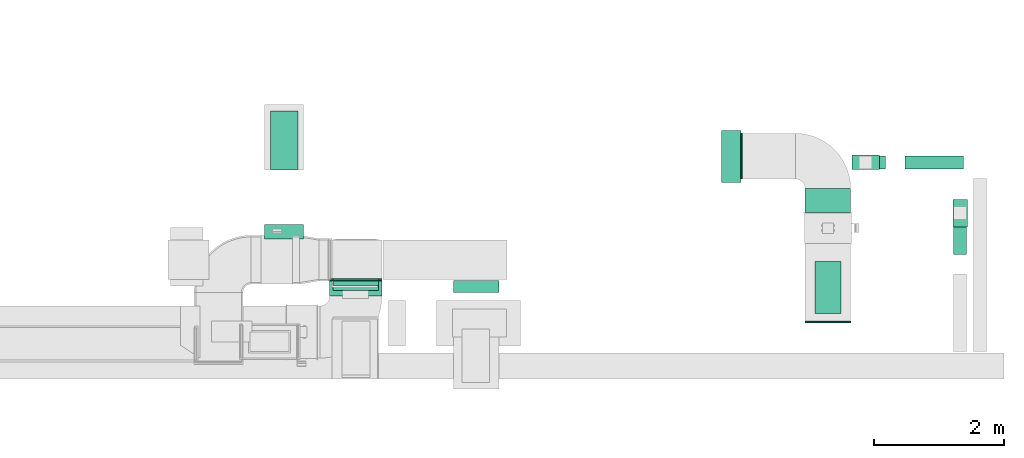
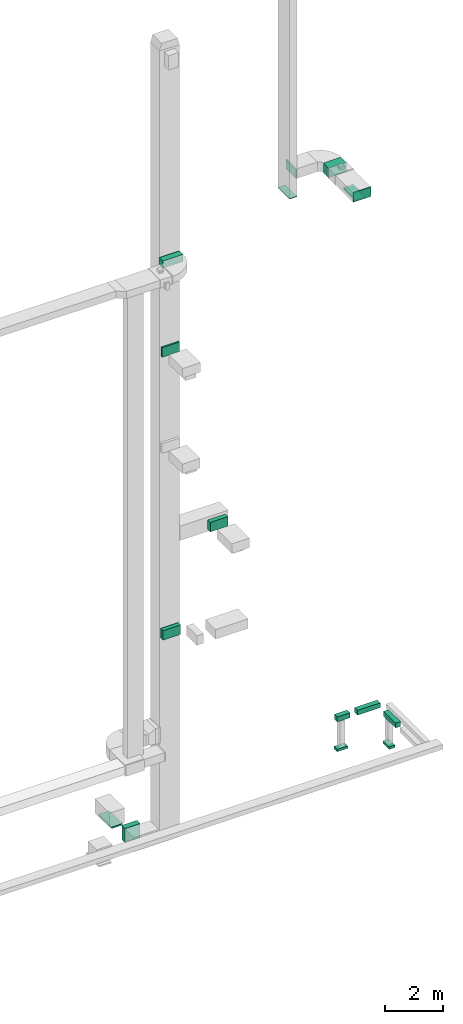
# One storey, part 17 of 29: 13 flow segments, 6 flow fittings, 1 flow terminal.
"""IFC2X3 building model written with IfcOpenShell, lengths in millimetres."""

from ifc_helpers import new_model, entity, si_unit, converted_unit, derived_unit, direction, frame, frame_2d, origin, origin_2d_with_axis, place, context, subcontext, project, spatial, rectangle, extrude, source, transform, mapped, material, type_object, type_shapes, element, save


model = new_model("IFC2X3")

# Units and contexts
model_context = context("Model", 3, precision=0.01, world=origin(), true_north=direction((6.12303176911189e-17, 1.0)))
body_context = subcontext(model_context, "Body", "Model", "MODEL_VIEW")
ifc_project = project(units=[si_unit("LENGTHUNIT", "METRE", prefix="MILLI"), si_unit("AREAUNIT", "SQUARE_METRE"), si_unit("VOLUMEUNIT", "CUBIC_METRE"), converted_unit("PLANEANGLEUNIT", "DEGREE", entity("IfcRatioMeasure", 0.0174532925199433), si_unit("PLANEANGLEUNIT", "RADIAN"), dimensions=[0, 0, 0, 0, 0, 0, 0]), si_unit("MASSUNIT", "GRAM", prefix="KILO"), derived_unit("MASSDENSITYUNIT", [(si_unit("MASSUNIT", "GRAM", prefix="KILO"), 1), (si_unit("LENGTHUNIT", "METRE"), -3)]), derived_unit("MOMENTOFINERTIAUNIT", [(si_unit("LENGTHUNIT", "METRE"), 4)]), si_unit("TIMEUNIT", "SECOND"), si_unit("FREQUENCYUNIT", "HERTZ"), si_unit("THERMODYNAMICTEMPERATUREUNIT", "DEGREE_CELSIUS"), derived_unit("THERMALTRANSMITTANCEUNIT", [(si_unit("MASSUNIT", "GRAM", prefix="KILO"), 1), (si_unit("THERMODYNAMICTEMPERATUREUNIT", "KELVIN"), -1), (si_unit("TIMEUNIT", "SECOND"), -3)]), derived_unit("VOLUMETRICFLOWRATEUNIT", [(si_unit("LENGTHUNIT", "METRE"), 3), (si_unit("TIMEUNIT", "SECOND"), -1)]), derived_unit("MASSFLOWRATEUNIT", [(si_unit("MASSUNIT", "GRAM", prefix="KILO"), 1), (si_unit("TIMEUNIT", "SECOND"), -1)]), derived_unit("ROTATIONALFREQUENCYUNIT", [(si_unit("TIMEUNIT", "SECOND"), -1)]), si_unit("ELECTRICCURRENTUNIT", "AMPERE"), si_unit("ELECTRICVOLTAGEUNIT", "VOLT"), si_unit("POWERUNIT", "WATT"), si_unit("FORCEUNIT", "NEWTON", prefix="KILO"), si_unit("ILLUMINANCEUNIT", "LUX"), si_unit("LUMINOUSFLUXUNIT", "LUMEN"), si_unit("LUMINOUSINTENSITYUNIT", "CANDELA"), derived_unit("USERDEFINED", [(si_unit("MASSUNIT", "GRAM", prefix="KILO"), -1), (si_unit("LENGTHUNIT", "METRE"), -2), (si_unit("TIMEUNIT", "SECOND"), 3), (si_unit("LUMINOUSFLUXUNIT", "LUMEN"), 1)]), derived_unit("LINEARVELOCITYUNIT", [(si_unit("LENGTHUNIT", "METRE"), 1), (si_unit("TIMEUNIT", "SECOND"), -1)]), si_unit("PRESSUREUNIT", "PASCAL"), derived_unit("USERDEFINED", [(si_unit("LENGTHUNIT", "METRE"), -2), (si_unit("MASSUNIT", "GRAM", prefix="KILO"), 1), (si_unit("TIMEUNIT", "SECOND"), -2)]), derived_unit("LINEARFORCEUNIT", [(si_unit("MASSUNIT", "GRAM", prefix="KILO"), 1), (si_unit("LENGTHUNIT", "METRE"), 1), (si_unit("TIMEUNIT", "SECOND"), -2), (si_unit("LENGTHUNIT", "METRE"), -1)]), derived_unit("PLANARFORCEUNIT", [(si_unit("MASSUNIT", "GRAM", prefix="KILO"), 1), (si_unit("LENGTHUNIT", "METRE"), 1), (si_unit("TIMEUNIT", "SECOND"), -2), (si_unit("LENGTHUNIT", "METRE"), -2)])], contexts=[model_context])

# Site, building, storey
site_placement = place(None, frame((0.0, -0.00077364408347762, 0.0)))
site = spatial("IfcSite", under=ifc_project, at=site_placement, CompositionType="ELEMENT")
building_placement = place(site_placement, origin())
building = spatial("IfcBuilding", under=site, at=building_placement, CompositionType="ELEMENT")
storey_placement = place(building_placement, origin())
storey = spatial("IfcBuildingStorey", under=building, at=storey_placement, CompositionType="ELEMENT", Elevation=0.0)

# Flow segments
duct_segment_type = type_object("IfcDuctSegmentType", PredefinedType="NOTDEFINED")
flow_segment_1_placement = place(storey_placement, frame((69919.8966022687, 9984.96833649774, 22730.0)))
element("IfcFlowSegment", 1, at=flow_segment_1_placement, inside=storey, type_object=duct_segment_type, context=body_context, shape_type="SweptSolid", body=[
    extrude(rectangle(XDim=800.0, YDim=400.000000000004, at=origin_2d_with_axis()), frame((200.0, 400.0, 0.0), z_axis=(0.0, 0.0, 1.0), x_axis=(0.0, 1.0, 0.0)), (0.0, 0.0, 1.0), 50.000000000006),
])
flow_segment_2_placement = place(storey_placement, frame((69769.8966022687, 11535.0, 22800.0)))
element("IfcFlowSegment", 2, at=flow_segment_2_placement, inside=storey, type_object=duct_segment_type, context=body_context, shape_type="SweptSolid", body=[
    extrude(rectangle(XDim=364.595053180721, YDim=699.999999999997, at=frame_2d((0.0, 4.32009983342141e-12), x_axis=(1.0, 0.0))), frame((350.0, 182.297526590368, 0.0), z_axis=(0.0, 0.0, 1.0), x_axis=(0.0, -1.0, 0.0)), (0.0, 0.0, 1.0), 399.999999999996),
])
flow_segment_3_placement = place(storey_placement, frame((61557.6339475038, 12193.4990444987, -1980.0)))
element("IfcFlowSegment", 3, at=flow_segment_3_placement, inside=storey, type_object=duct_segment_type, context=body_context, shape_type="SweptSolid", body=[
    extrude(rectangle(XDim=900.0, YDim=425.000000000004, at=frame_2d((-1.08002495835535e-12, 0.0), x_axis=(1.0, 0.0))), frame((212.502047009256, 450.000966639643, 0.0), z_axis=(0.0, 0.0, 1.0), x_axis=(4.54891432006358e-06, 1.0, 0.0)), (0.0, 0.0, 1.0), 60.4869889686039),
])
flow_segment_4_placement = place(storey_placement, frame((61470.135994513, 11128.5000111377, -1899.51301103141)))
element("IfcFlowSegment", 4, at=flow_segment_4_placement, inside=storey, type_object=duct_segment_type, context=body_context, shape_type="SweptSolid", body=[
    extrude(rectangle(XDim=221.220937838014, YDim=600.000000000002, at=frame_2d((1.08002495835535e-12, 0.0), x_axis=(1.0, 0.0))), frame((300.0, 110.610468919006, 0.0), z_axis=(0.0, 0.0, 1.0), x_axis=(0.0, 1.0, 0.0)), (0.0, 0.0, 1.0), 600.0),
])
flow_segment_5_placement = place(storey_placement, frame((72050.4589684754, 10887.2569885968, -650.0)))
element("IfcFlowSegment", 5, at=flow_segment_5_placement, inside=storey, type_object=duct_segment_type, context=body_context, shape_type="SweptSolid", body=[
    extrude(rectangle(XDim=834.396194023908, YDim=199.999999999998, at=frame_2d((-1.08002495835535e-12, -4.33431068813661e-12), x_axis=(1.0, 0.0))), frame((100.0, 417.198097011955, 0.0), z_axis=(0.0, 0.0, 1.0), x_axis=(0.0, 1.0, 0.0)), (0.0, 0.0, 1.0), 200.0),
])
flow_segment_6_placement = place(storey_placement, frame((70499.2346294125, 12205.499847268, -650.0)))
element("IfcFlowSegment", 6, at=flow_segment_6_placement, inside=storey, type_object=duct_segment_type, context=body_context, shape_type="SweptSolid", body=[
    extrude(rectangle(XDim=507.012116293382, YDim=200.0, at=frame_2d((-4.33431068813661e-12, -1.08713038571295e-12), x_axis=(1.0, 0.0))), frame((253.506058146695, 100.0, 0.0), z_axis=(0.0, 0.0, 1.0), x_axis=(-1.0, 0.0, 0.0)), (0.0, 0.0, 1.0), 200.0),
])
flow_segment_7_placement = place(storey_placement, frame((71306.2467457059, 12205.499847268, -650.0)))
element("IfcFlowSegment", 7, at=flow_segment_7_placement, inside=storey, type_object=duct_segment_type, context=body_context, shape_type="SweptSolid", body=[
    extrude(rectangle(XDim=898.086611318234, YDim=200.0, at=frame_2d((4.34852154285181e-12, 2.16715534406831e-12), x_axis=(1.0, 0.0))), frame((449.043305659121, 100.0, 0.0), z_axis=(0.0, 0.0, 1.0), x_axis=(-1.0, 0.0, 0.0)), (0.0, 0.0, 1.0), 200.0),
])
flow_segment_8_placement = place(storey_placement, frame((72037.9589684754, 11312.4032421629, -1800.0)))
element("IfcFlowSegment", 8, at=flow_segment_8_placement, inside=storey, type_object=duct_segment_type, context=body_context, shape_type="SweptSolid", body=[
    extrude(rectangle(XDim=425.000000000007, YDim=225.000000000001, at=origin_2d_with_axis()), frame((112.5, 212.500000000004, 0.0), z_axis=(0.0, 0.0, 1.0), x_axis=(0.0, -1.0, 0.0)), (0.0, 0.0, 1.0), 100.0),
])
flow_segment_9_placement = place(storey_placement, frame((70486.7346294125, 12192.999847268, -1894.0)))
element("IfcFlowSegment", 9, at=flow_segment_9_placement, inside=storey, type_object=duct_segment_type, context=body_context, shape_type="SweptSolid", body=[
    extrude(rectangle(XDim=425.000000000007, YDim=225.000000000001, at=frame_2d((0.0, 1.08002495835535e-12), x_axis=(1.0, 0.0))), frame((212.500000000004, 112.5, 0.0)), (0.0, 0.0, 1.0), 100.0),
])
flow_segment_10_placement = place(storey_placement, frame((62518.988759683, 10412.601109398, 18500.0)))
element("IfcFlowSegment", 10, at=flow_segment_10_placement, inside=storey, type_object=duct_segment_type, context=body_context, shape_type="SweptSolid", body=[
    extrude(rectangle(XDim=71.0457855893592, YDim=700.000000000003, at=origin_2d_with_axis()), frame((350.005588994264, 35.5780023522402, 0.0), z_axis=(0.0, 0.0, 1.0), x_axis=(-0.000157457136900827, 0.999999987603625, 0.0)), (0.0, 0.0, 1.0), 400.0),
])
flow_segment_11_placement = place(storey_placement, frame((62469.7193441226, 10248.8325484295, 22350.0)))
element("IfcFlowSegment", 11, at=flow_segment_11_placement, inside=storey, type_object=duct_segment_type, context=body_context, shape_type="SweptSolid", body=[
    extrude(rectangle(XDim=239.665570609249, YDim=800.000000000004, at=frame_2d((1.08713038571295e-12, 4.32009983342141e-12), x_axis=(1.0, 0.0))), frame((400.000412244298, 119.834161376974, 0.0), z_axis=(0.0, 0.0, 1.0), x_axis=(-3.44018263539569e-06, -1.0, 0.0)), (0.0, 0.0, 1.0), 300.000000000001),
])
flow_segment_12_placement = place(storey_placement, frame((62520.6816618024, 10335.385873386, 6700.0)))
element("IfcFlowSegment", 12, at=flow_segment_12_placement, inside=storey, type_object=duct_segment_type, context=body_context, shape_type="SweptSolid", body=[
    extrude(rectangle(XDim=153.114137751644, YDim=699.999999999997, at=frame_2d((0.0, -4.32009983342141e-12), x_axis=(1.0, 0.0))), frame((350.0, 76.5570688758424, 0.0), z_axis=(0.0, 0.0, 1.0), x_axis=(0.0, 1.0, 0.0)), (0.0, 0.0, 1.0), 400.0),
])
flow_segment_13_placement = place(storey_placement, frame((64372.3098713498, 10305.6563298071, 10600.0)))
element("IfcFlowSegment", 13, at=flow_segment_13_placement, inside=storey, type_object=duct_segment_type, context=body_context, shape_type="SweptSolid", body=[
    extrude(rectangle(XDim=182.843681330892, YDim=699.999999999997, at=frame_2d((1.08713038571295e-12, 0.0), x_axis=(1.0, 0.0))), frame((350.0, 91.421840665447, 0.0), z_axis=(0.0, 0.0, 1.0), x_axis=(0.0, 1.0, 0.0)), (0.0, 0.0, 1.0), 400.0),
])

# Flow fitting
ifc_material_1 = material()
duct_fitting_type_1 = type_object("IfcDuctFittingType", PredefinedType="NOTDEFINED", material=ifc_material_1)
shared_shape_1 = source(origin(), body_context, "Body", "SweptSolid", [
    extrude(rectangle(XDim=24.9999999999999, YDim=700.0, at=frame_2d((-2.89546164822241e-13, 5.6843418860808e-14), x_axis=(1.0, 0.0))), frame((12.500000000006, 0.0, -200.0)), (0.0, 0.0, 1.0), 400.0),
])
type_shapes(duct_fitting_type_1, [shared_shape_1])
flow_fitting_1_placement = place(storey_placement, frame((70119.8966022688, 9867.90456577983, 23000.0), z_axis=(0.0, 0.0, 1.0), x_axis=(0.0, -1.0, 0.0)))
element("IfcFlowFitting", 14, at=flow_fitting_1_placement, inside=storey, type_object=duct_fitting_type_1, material=ifc_material_1, context=body_context, shape_type="MappedRepresentation", body=[
    mapped(shared_shape_1, transform((0.0, 0.0, 0.0), scale=1.0)),
])

# Flow terminal
ifc_material_2 = material()
air_terminal_type = type_object("IfcAirTerminalType", PredefinedType="NOTDEFINED", material=ifc_material_2)
shared_shape_2 = source(origin(), body_context, "Body", "SweptSolid", [
    extrude(rectangle(XDim=4.0, YDim=799.999999999999, at=origin_2d_with_axis()), frame((0.0, -2.0, -200.0), z_axis=(0.0, 0.0, 1.0), x_axis=(0.0, 1.0, 0.0)), (0.0, 0.0, 1.0), 400.000000000005),
])
type_shapes(air_terminal_type, [shared_shape_2])
flow_terminal_placement = place(storey_placement, frame((70119.8966022687, 10384.9683364977, 22730.0), z_axis=(1.0, 0.0, 0.0), x_axis=(0.0, 1.0, 0.0)))
element("IfcFlowTerminal", 15, at=flow_terminal_placement, inside=storey, type_object=air_terminal_type, material=ifc_material_2, context=body_context, shape_type="MappedRepresentation", body=[
    mapped(shared_shape_2, transform((0.0, 0.0, 0.0), scale=1.0)),
])

# Flow fittings
duct_fitting_type_2 = type_object("IfcDuctFittingType", PredefinedType="NOTDEFINED", material=ifc_material_1)
shared_shape_3 = source(origin(), body_context, "Body", "SweptSolid", [
    extrude(rectangle(XDim=26.0960000000006, YDim=400.0, at=frame_2d((-3.10862446895044e-13, -1.4210854715202e-13), x_axis=(1.0, 0.0))), frame((6.95199999999999, 0.0, -350.0)), (0.0, 0.0, 1.0), 700.0),
])
type_shapes(duct_fitting_type_2, [shared_shape_3])
for number, where, z_axis, x_axis in (
    (16, (68787.4986476513, 12399.5950531686, 23000.0), (0.0, -1.0, 0.0), (1.0, 0.0, 0.0)),
    (17, (62870.6816618024, 10508.5000111377, 6900.0), (-1.0, 0.0, 0.0), (0.0, -1.0, 0.0)),
):
    element("IfcFlowFitting", number, at=place(storey_placement, frame(where, z_axis=z_axis, x_axis=x_axis)), inside=storey, type_object=duct_fitting_type_2, material=ifc_material_1, context=body_context, shape_type="MappedRepresentation", body=[
        mapped(shared_shape_3, transform((0.0, 0.0, 0.0), scale=1.0)),
    ])
duct_fitting_type_3 = type_object("IfcDuctFittingType", PredefinedType="NOTDEFINED", material=ifc_material_1)
shared_shape_4 = source(origin(), body_context, "Body", "SweptSolid", [
    extrude(rectangle(XDim=400.0, YDim=26.0960000000022, at=origin_2d_with_axis()), frame((6.95199999999999, 0.0, -400.0), z_axis=(0.0, 0.0, 1.0), x_axis=(0.0, -1.0, 0.0)), (0.0, 0.0, 1.0), 800.0),
])
type_shapes(duct_fitting_type_3, [shared_shape_4])
flow_fitting_2_placement = place(storey_placement, frame((70119.8966022687, 10384.9683364977, 22800.0), z_axis=(0.0, -1.0, 0.0), x_axis=(0.0, 0.0, -1.0)))
element("IfcFlowFitting", 18, at=flow_fitting_2_placement, inside=storey, type_object=duct_fitting_type_3, material=ifc_material_1, context=body_context, shape_type="MappedRepresentation", body=[
    mapped(shared_shape_4, transform((0.0, 0.0, 0.0), scale=1.0)),
])
duct_fitting_type_4 = type_object("IfcDuctFittingType", PredefinedType="NOTDEFINED", material=ifc_material_1)
shared_shape_5 = source(origin(), body_context, "Body", "SweptSolid", [
    extrude(rectangle(XDim=24.9999999999999, YDim=300.0, at=frame_2d((-1.25233157177718e-13, 1.4210854715202e-14), x_axis=(1.0, 0.0))), frame((12.5000000000061, 0.0, -400.0)), (0.0, 0.0, 1.0), 800.0),
])
type_shapes(duct_fitting_type_4, [shared_shape_5])
flow_fitting_3_placement = place(storey_placement, frame((68637.4986476513, 12392.5950531686, 22100.0), z_axis=(0.0, -1.0, 0.0), x_axis=(0.0, 0.0, -1.0)))
element("IfcFlowFitting", 19, at=flow_fitting_3_placement, inside=storey, type_object=duct_fitting_type_4, material=ifc_material_1, context=body_context, shape_type="MappedRepresentation", body=[
    mapped(shared_shape_5, transform((0.0, 0.0, 0.0), scale=1.0)),
])
duct_fitting_type_5 = type_object("IfcDuctFittingType", PredefinedType="NOTDEFINED", material=ifc_material_1)
shared_shape_6 = source(origin(), body_context, "Body", "SweptSolid", [
    extrude(rectangle(XDim=26.0970320547895, YDim=300.0, at=frame_2d((-2.32702745961433e-13, -9.9475983006414e-14), x_axis=(1.0, 0.0))), frame((6.95199999999782, 0.0, -400.0)), (0.0, 0.0, 1.0), 800.0),
])
type_shapes(duct_fitting_type_5, [shared_shape_6])
flow_fitting_4_placement = place(storey_placement, frame((62869.720237419, 10508.5000111377, 22500.0), z_axis=(-1.0, 3.44018264489101e-06, 0.0), x_axis=(-3.44018264489101e-06, -1.0, 0.0)))
element("IfcFlowFitting", 20, at=flow_fitting_4_placement, inside=storey, type_object=duct_fitting_type_5, material=ifc_material_1, context=body_context, shape_type="MappedRepresentation", body=[
    mapped(shared_shape_6, transform((0.0, 0.0, 0.0), scale=1.0)),
])

save(model, "model.ifc")
